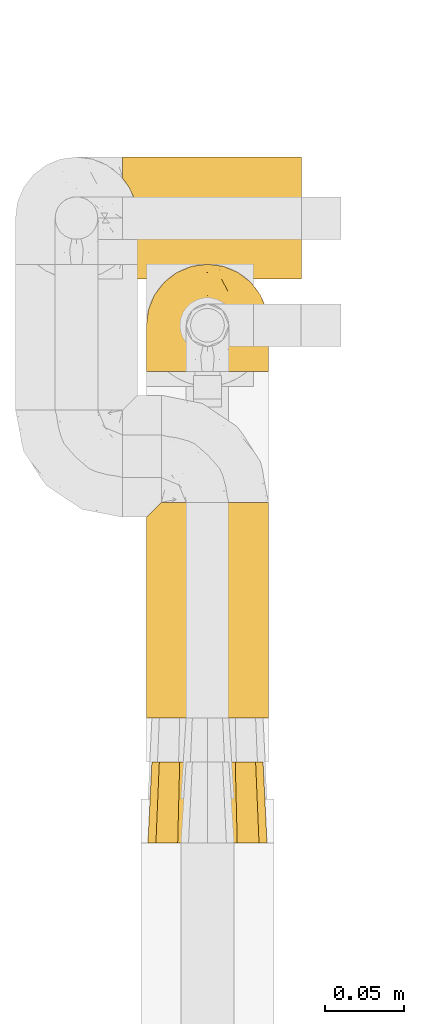
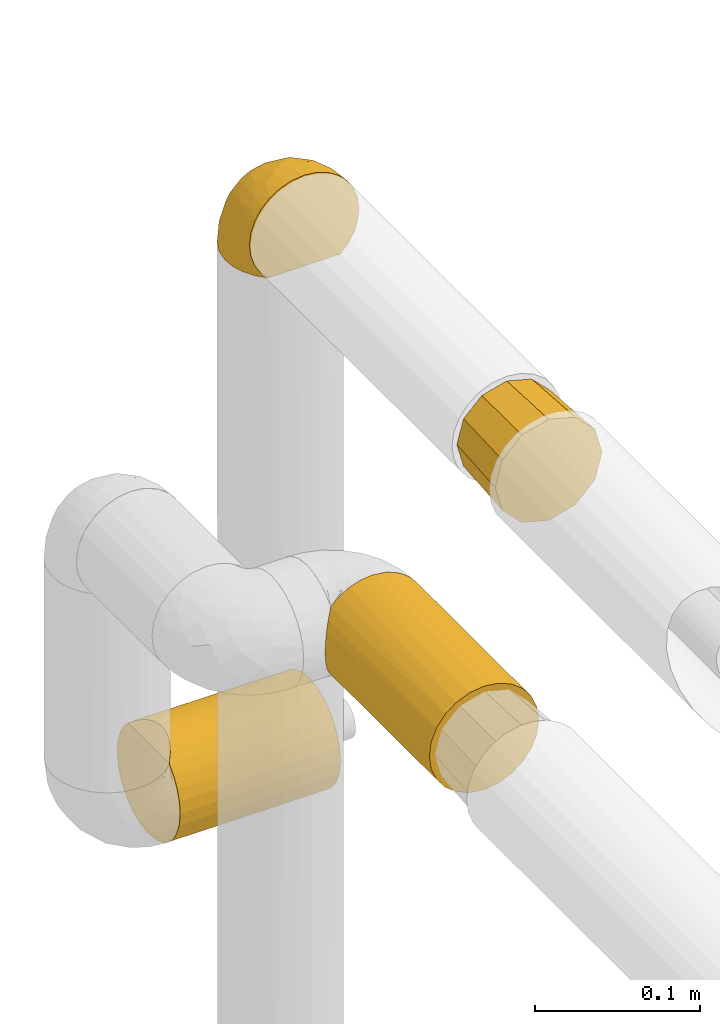
# One storey, part 110 of 827: 4 coverings.
"""IFC2X3 building model written with IfcOpenShell, lengths in millimetres."""

from ifc_helpers import new_model, entity, si_unit, converted_unit, derived_unit, direction, frame, origin, place, context, subcontext, project, spatial, faceted_brep, element, save


model = new_model("IFC2X3")

# Units and contexts
model_context = context("Model", 3, precision=0.01, world=origin(), true_north=direction((6.12303176911189e-17, 1.0)))
body_context = subcontext(model_context, "Body", "Model", "MODEL_VIEW")
ifc_project = project(units=[si_unit("LENGTHUNIT", "METRE", prefix="MILLI"), si_unit("AREAUNIT", "SQUARE_METRE"), si_unit("VOLUMEUNIT", "CUBIC_METRE"), converted_unit("PLANEANGLEUNIT", "DEGREE", entity("IfcRatioMeasure", 0.0174532925199433), si_unit("PLANEANGLEUNIT", "RADIAN"), dimensions=[0, 0, 0, 0, 0, 0, 0]), si_unit("MASSUNIT", "GRAM", prefix="KILO"), derived_unit("MASSDENSITYUNIT", [(si_unit("MASSUNIT", "GRAM", prefix="KILO"), 1), (si_unit("LENGTHUNIT", "METRE"), -3)]), derived_unit("MOMENTOFINERTIAUNIT", [(si_unit("LENGTHUNIT", "METRE"), 4)]), si_unit("TIMEUNIT", "SECOND"), si_unit("FREQUENCYUNIT", "HERTZ"), si_unit("THERMODYNAMICTEMPERATUREUNIT", "DEGREE_CELSIUS"), derived_unit("THERMALTRANSMITTANCEUNIT", [(si_unit("MASSUNIT", "GRAM", prefix="KILO"), 1), (si_unit("THERMODYNAMICTEMPERATUREUNIT", "KELVIN"), -1), (si_unit("TIMEUNIT", "SECOND"), -3)]), derived_unit("VOLUMETRICFLOWRATEUNIT", [(si_unit("LENGTHUNIT", "METRE"), 3), (si_unit("TIMEUNIT", "SECOND"), -1)]), derived_unit("MASSFLOWRATEUNIT", [(si_unit("MASSUNIT", "GRAM", prefix="KILO"), 1), (si_unit("TIMEUNIT", "SECOND"), -1)]), derived_unit("ROTATIONALFREQUENCYUNIT", [(si_unit("TIMEUNIT", "SECOND"), -1)]), si_unit("ELECTRICCURRENTUNIT", "AMPERE"), si_unit("ELECTRICVOLTAGEUNIT", "VOLT"), si_unit("POWERUNIT", "WATT"), si_unit("FORCEUNIT", "NEWTON", prefix="KILO"), si_unit("ILLUMINANCEUNIT", "LUX"), si_unit("LUMINOUSFLUXUNIT", "LUMEN"), si_unit("LUMINOUSINTENSITYUNIT", "CANDELA"), derived_unit("USERDEFINED", [(si_unit("MASSUNIT", "GRAM", prefix="KILO"), -1), (si_unit("LENGTHUNIT", "METRE"), -2), (si_unit("TIMEUNIT", "SECOND"), 3), (si_unit("LUMINOUSFLUXUNIT", "LUMEN"), 1)]), derived_unit("LINEARVELOCITYUNIT", [(si_unit("LENGTHUNIT", "METRE"), 1), (si_unit("TIMEUNIT", "SECOND"), -1)]), si_unit("PRESSUREUNIT", "PASCAL"), derived_unit("USERDEFINED", [(si_unit("LENGTHUNIT", "METRE"), -2), (si_unit("MASSUNIT", "GRAM", prefix="KILO"), 1), (si_unit("TIMEUNIT", "SECOND"), -2)]), derived_unit("LINEARFORCEUNIT", [(si_unit("MASSUNIT", "GRAM", prefix="KILO"), 1), (si_unit("LENGTHUNIT", "METRE"), 1), (si_unit("TIMEUNIT", "SECOND"), -2), (si_unit("LENGTHUNIT", "METRE"), -1)]), derived_unit("PLANARFORCEUNIT", [(si_unit("MASSUNIT", "GRAM", prefix="KILO"), 1), (si_unit("LENGTHUNIT", "METRE"), 1), (si_unit("TIMEUNIT", "SECOND"), -2), (si_unit("LENGTHUNIT", "METRE"), -2)])], contexts=[model_context])

# Site, building, storey
site_placement = place(None, origin())
site = spatial("IfcSite", under=ifc_project, at=site_placement, CompositionType="ELEMENT")
building_placement = place(site_placement, origin())
building = spatial("IfcBuilding", under=site, at=building_placement, CompositionType="ELEMENT")
storey_placement = place(building_placement, frame((0.0, 0.0, 28200.0)))
storey = spatial("IfcBuildingStorey", under=building, at=storey_placement, Name="08", CompositionType="ELEMENT", Elevation=28200.0)

# Coverings
covering_1_placement = place(storey_placement, frame((19736.22, 11790.36, 1773.88)))
element("IfcCovering", 1, at=covering_1_placement, inside=storey, Name=":ADSK_", ObjectType=":ADSK_", PredefinedType="INSULATION", context=body_context, shape_type="Brep", body=[
    faceted_brep([(74.68, 1.6, 47.38), (70.1, 1.6, 54.67), (64.01, 1.6, 60.76), (56.72, 1.6, 65.34), (48.6, 1.6, 68.18), (40.05, 1.6, 69.15), (31.49, 1.6, 68.18), (23.36, 1.6, 65.33), (16.07, 1.6, 60.75), (9.98, 1.6, 54.66), (5.4, 1.6, 47.37), (2.56, 1.6, 39.25), (1.6, 1.6, 30.7), (2.46, 1.6, 22.59), (5.01, 1.6, 14.86), (9.13, 1.6, 7.84), (14.62, 1.6, 1.85), (16.82, 1.6, 1.85), (18.56, 1.6, 1.85), (20.52, 1.6, 1.85), (22.49, 1.6, 1.85), (24.46, 1.6, 1.85), (26.42, 1.6, 1.85), (28.39, 1.6, 1.85), (30.36, 1.6, 1.85), (32.55, 1.6, 1.85), (34.75, 1.6, 1.85), (36.94, 1.6, 1.85), (39.13, 1.6, 1.85), (41.33, 1.6, 1.85), (43.52, 1.6, 1.85), (45.72, 1.6, 1.85), (47.91, 1.6, 1.85), (50.11, 1.6, 1.85), (52.3, 1.6, 1.85), (54.49, 1.6, 1.85), (56.69, 1.6, 1.85), (58.88, 1.6, 1.85), (61.08, 1.6, 1.85), (63.27, 1.6, 1.85), (65.47, 1.6, 1.85), (70.97, 1.6, 7.85), (75.09, 1.6, 14.88), (77.64, 1.6, 22.61), (78.5, 1.6, 30.7), (77.53, 1.6, 39.26), (14.62, 1.85, 1.6), (9.12, 7.85, 1.6), (5.0, 14.87, 1.6), (2.46, 22.6, 1.6), (1.6, 30.7, 1.6), (2.91, 40.65, 1.6), (6.75, 49.92, 1.6), (12.86, 57.88, 1.6), (20.82, 63.99, 1.6), (30.09, 67.84, 1.6), (40.05, 69.15, 1.6), (50.0, 67.84, 1.6), (59.27, 63.99, 1.6), (67.23, 57.88, 1.6), (73.34, 49.92, 1.6), (77.19, 40.65, 1.6), (78.5, 30.7, 1.6), (77.63, 22.6, 1.6), (75.09, 14.87, 1.6), (70.97, 7.85, 1.6), (65.47, 1.85, 1.6), (63.27, 1.85, 1.6), (62.29, 1.85, 1.6), (60.7, 1.85, 1.6), (59.11, 1.85, 1.6), (57.52, 1.85, 1.6), (55.93, 1.85, 1.6), (54.34, 1.85, 1.6), (52.76, 1.85, 1.6), (51.17, 1.85, 1.6), (49.58, 1.85, 1.6), (47.99, 1.85, 1.6), (46.4, 1.85, 1.6), (44.81, 1.85, 1.6), (43.22, 1.85, 1.6), (41.63, 1.85, 1.6), (40.05, 1.85, 1.6), (38.46, 1.85, 1.6), (36.87, 1.85, 1.6), (35.28, 1.85, 1.6), (33.69, 1.85, 1.6), (32.1, 1.85, 1.6), (30.51, 1.85, 1.6), (28.92, 1.85, 1.6), (27.33, 1.85, 1.6), (25.37, 1.85, 1.6), (23.4, 1.85, 1.6), (21.21, 1.85, 1.6), (19.01, 1.85, 1.6), (16.82, 1.85, 1.6), (42.32, 1.77, 1.78), (44.02, 1.78, 1.77), (47.13, 1.77, 1.78), (48.74, 1.77, 1.77), (23.57, 1.76, 1.79), (25.13, 1.77, 1.78), (61.34, 1.79, 1.76), (22.02, 1.78, 1.77), (29.72, 1.78, 1.77), (56.73, 1.78, 1.76), (55.14, 1.78, 1.77), (37.66, 1.78, 1.77), (64.12, 1.74, 1.8), (28.13, 1.78, 1.76), (26.62, 1.78, 1.77), (31.46, 1.77, 1.78), (16.16, 1.78, 1.77), (39.16, 1.78, 1.77), (50.37, 1.78, 1.76), (17.69, 1.77, 1.77), (19.17, 1.77, 1.78), (62.78, 1.77, 1.77), (58.35, 1.78, 1.77), (45.53, 1.78, 1.77), (59.91, 1.77, 1.78), (65.47, 1.77, 1.77), (65.47, 1.72, 1.8), (65.47, 1.66, 1.82), (14.62, 1.77, 1.77), (14.62, 1.8, 1.72), (14.62, 1.82, 1.66), (20.59, 1.79, 1.76), (32.99, 1.78, 1.77), (34.48, 1.79, 1.76), (51.91, 1.78, 1.77), (65.47, 1.82, 1.66), (65.47, 1.8, 1.72), (53.48, 1.76, 1.78), (14.62, 1.66, 1.82), (14.62, 1.72, 1.8), (40.77, 1.78, 1.77), (35.97, 1.77, 1.78), (7.84, 9.41, 3.72), (3.53, 17.65, 7.41), (8.32, 7.41, 6.13), (1.6, 21.47, 21.47), (2.19, 15.21, 19.34), (1.6, 16.15, 26.8), (1.6, 28.75, 8.87), (4.57, 13.67, 9.2), (3.96, 12.79, 12.79), (2.28, 19.18, 14.62), (1.6, 29.16, 7.34), (7.69, 9.04, 5.33), (3.53, 7.41, 17.64), (8.32, 5.74, 7.7), (7.84, 3.72, 9.41), (1.6, 8.87, 28.75), (1.6, 26.8, 16.15), (4.34, 9.53, 14.14), (1.6, 7.34, 29.16), (29.63, 37.63, 57.02), (27.34, 17.92, 64.92), (40.05, 27.45, 64.0), (2.39, 37.01, 11.92), (2.43, 34.22, 19.16), (9.07, 45.87, 28.65), (16.64, 56.57, 24.62), (9.54, 52.31, 15.19), (4.52, 42.07, 18.36), (4.52, 44.74, 9.2), (7.49, 21.49, 46.98), (7.49, 11.02, 50.24), (12.85, 15.64, 56.1), (2.35, 26.02, 28.97), (22.66, 36.59, 54.46), (32.9, 65.49, 21.34), (25.33, 63.99, 18.4), (40.05, 15.2, 66.44), (16.64, 60.27, 12.07), (19.99, 45.25, 45.49), (16.37, 35.21, 50.57), (3.26, 22.52, 36.04), (3.75, 12.03, 42.07), (19.58, 13.32, 62.12), (7.5, 35.9, 37.37), (4.04, 33.87, 29.39), (13.94, 25.73, 53.59), (19.58, 26.34, 58.06), (28.21, 46.78, 49.27), (24.75, 59.54, 29.63), (31.42, 60.18, 33.21), (26.2, 53.93, 40.1), (33.36, 53.36, 44.08), (40.05, 49.36, 49.36), (40.05, 38.4, 56.68), (40.05, 66.44, 15.2), (16.14, 50.09, 35.57), (12.85, 41.08, 41.7), (10.47, 31.14, 46.4), (6.49, 28.19, 41.41), (40.05, 64.0, 27.45), (40.05, 56.68, 38.4), (75.57, 43.9, 12.99), (47.37, 65.46, 21.33), (52.91, 52.22, 42.89), (50.46, 37.61, 57.04), (67.23, 15.64, 56.11), (60.5, 13.31, 62.13), (70.55, 50.02, 21.89), (63.45, 59.28, 16.62), (62.61, 53.05, 32.9), (72.6, 21.48, 46.99), (72.6, 11.01, 50.25), (76.34, 12.03, 42.08), (59.34, 41.02, 49.91), (77.76, 35.39, 15.6), (78.5, 26.8, 16.15), (78.5, 28.75, 8.87), (78.5, 7.34, 29.16), (53.16, 65.81, 13.16), (70.55, 53.28, 10.83), (48.88, 59.8, 33.8), (54.76, 61.82, 25.02), (52.74, 17.91, 64.92), (71.93, 41.4, 32.83), (75.79, 40.48, 20.56), (60.5, 26.34, 58.07), (77.86, 31.68, 21.46), (77.64, 27.68, 28.1), (78.5, 16.15, 26.8), (78.5, 21.47, 21.47), (67.23, 28.05, 51.29), (76.82, 22.54, 36.04), (78.5, 8.87, 28.75), (77.8, 37.3, 8.45), (67.23, 41.07, 41.73), (73.2, 32.24, 39.27), (67.66, 47.4, 33.56), (75.99, 35.77, 27.29), (76.57, 17.65, 7.41), (73.21, 11.06, 3.51), (71.93, 8.55, 4.68), (71.07, 6.63, 5.52), (75.09, 12.77, 8.75), (76.13, 12.79, 12.79), (76.57, 7.41, 17.65), (77.69, 18.97, 13.9), (72.26, 3.72, 9.42), (71.77, 5.76, 7.68), (77.9, 15.21, 19.33), (75.75, 9.52, 14.13)], [[[0, 1, 2, 3, 4, 5, 6, 7, 8, 9, 10, 11, 12, 13, 14, 15, 16, 17, 18, 19, 20, 21, 22, 23, 24, 25, 26, 27, 28, 29, 30, 31, 32, 33, 34, 35, 36, 37, 38, 39, 40, 41, 42, 43, 44, 45]], [[46, 47, 48, 49, 50, 51, 52, 53, 54, 55, 56, 57, 58, 59, 60, 61, 62, 63, 64, 65, 66, 67, 68, 69, 70, 71, 72, 73, 74, 75, 76, 77, 78, 79, 80, 81, 82, 83, 84, 85, 86, 87, 88, 89, 90, 91, 92, 93, 94, 95]], [[96, 97, 30]], [[98, 77, 99]], [[100, 101, 21]], [[69, 68, 102]], [[20, 19, 103]], [[24, 23, 104]], [[20, 103, 100]], [[72, 105, 106]], [[84, 83, 107]], [[89, 88, 104]], [[108, 67, 66]], [[109, 110, 90]], [[111, 25, 24]], [[112, 17, 16]], [[82, 113, 83]], [[109, 23, 22]], [[114, 76, 75]], [[105, 36, 106]], [[104, 111, 24]], [[18, 115, 116]], [[97, 96, 80]], [[67, 108, 117]], [[105, 71, 118]], [[31, 97, 119]], [[102, 120, 69]], [[108, 121, 122, 123, 40]], [[112, 95, 115]], [[17, 115, 18]], [[94, 116, 115]], [[117, 68, 67]], [[38, 117, 39]], [[112, 124, 125, 126, 46]], [[17, 112, 115]], [[70, 120, 118]], [[39, 117, 108]], [[120, 38, 37]], [[120, 37, 118]], [[120, 70, 69]], [[116, 94, 127]], [[128, 86, 129]], [[117, 38, 102]], [[74, 130, 75]], [[99, 33, 32]], [[115, 95, 94]], [[39, 108, 40]], [[108, 66, 131, 132, 121]], [[105, 72, 71]], [[118, 37, 36]], [[71, 70, 118]], [[35, 106, 36]], [[36, 105, 118]], [[35, 133, 106]], [[74, 73, 133]], [[106, 133, 73]], [[99, 114, 33]], [[133, 35, 34]], [[73, 72, 106]], [[95, 112, 46]], [[112, 16, 134, 135, 124]], [[130, 114, 75]], [[99, 76, 114]], [[114, 130, 33]], [[34, 33, 130]], [[78, 77, 98]], [[98, 119, 78]], [[130, 133, 34]], [[133, 130, 74]], [[79, 97, 80]], [[98, 99, 32]], [[98, 32, 31]], [[77, 76, 99]], [[97, 79, 119]], [[136, 96, 29]], [[30, 97, 31]], [[136, 29, 28]], [[81, 80, 96]], [[29, 96, 30]], [[31, 119, 98]], [[119, 79, 78]], [[96, 136, 81]], [[82, 81, 136]], [[113, 107, 83]], [[84, 107, 137]], [[107, 27, 137]], [[113, 28, 107]], [[27, 107, 28]], [[85, 84, 137]], [[137, 27, 26]], [[113, 136, 28]], [[136, 113, 82]], [[109, 89, 104]], [[86, 85, 129]], [[89, 109, 90]], [[111, 87, 128]], [[26, 129, 137]], [[88, 111, 104]], [[25, 111, 128]], [[22, 110, 109]], [[23, 109, 104]], [[110, 91, 90]], [[100, 92, 101]], [[110, 22, 101]], [[91, 110, 101]], [[116, 19, 18]], [[111, 88, 87]], [[127, 103, 19]], [[25, 128, 26]], [[86, 128, 87]], [[128, 129, 26]], [[137, 129, 85]], [[120, 102, 38]], [[117, 102, 68]], [[91, 101, 92]], [[21, 101, 22]], [[93, 92, 103]], [[100, 21, 20]], [[100, 103, 92]], [[127, 93, 103]], [[93, 127, 94]], [[116, 127, 19]], [[126, 138, 47]], [[48, 138, 139]], [[140, 125, 124]], [[141, 142, 143]], [[144, 49, 139]], [[145, 140, 146]], [[48, 139, 49]], [[139, 145, 147]], [[49, 144, 148, 50]], [[126, 125, 149]], [[14, 13, 150]], [[151, 146, 140]], [[149, 140, 145]], [[152, 151, 135]], [[152, 14, 150]], [[16, 15, 134]], [[13, 153, 150]], [[124, 151, 140]], [[141, 147, 142]], [[14, 152, 15]], [[15, 152, 134]], [[47, 46, 126]], [[139, 154, 144]], [[138, 48, 47]], [[125, 140, 149]], [[135, 134, 152]], [[146, 155, 142]], [[145, 146, 147]], [[149, 139, 138]], [[147, 141, 154]], [[147, 146, 142]], [[139, 147, 154]], [[139, 149, 145]], [[149, 138, 126]], [[155, 146, 151]], [[150, 143, 142]], [[152, 155, 151]], [[150, 142, 155]], [[13, 12, 156, 153]], [[153, 143, 150]], [[152, 150, 155]], [[151, 124, 135]], [[157, 158, 159]], [[160, 154, 161]], [[162, 163, 164]], [[165, 166, 160]], [[167, 168, 169]], [[141, 170, 161]], [[156, 12, 11]], [[158, 157, 171]], [[172, 55, 173]], [[158, 6, 174]], [[175, 54, 53]], [[52, 166, 164]], [[52, 164, 53]], [[54, 175, 173]], [[166, 52, 51]], [[176, 177, 171]], [[178, 143, 179]], [[156, 11, 179]], [[8, 7, 180]], [[169, 9, 8]], [[179, 143, 153, 156]], [[179, 11, 10]], [[168, 179, 10]], [[181, 162, 182]], [[179, 167, 178]], [[183, 184, 177]], [[183, 169, 184]], [[176, 171, 185]], [[172, 186, 187]], [[158, 7, 6]], [[159, 158, 174]], [[184, 180, 158]], [[54, 173, 55]], [[180, 169, 8]], [[188, 189, 187]], [[9, 168, 10]], [[186, 188, 187]], [[190, 157, 159, 191]], [[55, 172, 192]], [[176, 193, 194]], [[161, 170, 182]], [[162, 164, 165]], [[175, 164, 163]], [[51, 50, 148]], [[167, 195, 196]], [[178, 182, 170]], [[6, 5, 174]], [[158, 180, 7]], [[169, 180, 184]], [[169, 168, 9]], [[179, 168, 167]], [[182, 162, 165]], [[162, 194, 193]], [[161, 165, 160]], [[195, 181, 196]], [[192, 172, 197]], [[192, 56, 55]], [[189, 190, 198]], [[198, 197, 187]], [[172, 187, 197]], [[185, 189, 188]], [[198, 187, 189]], [[186, 172, 173]], [[173, 163, 186]], [[193, 186, 163]], [[176, 185, 188]], [[185, 157, 190]], [[188, 186, 193]], [[177, 176, 194]], [[188, 193, 176]], [[162, 193, 163]], [[195, 177, 194]], [[171, 177, 184]], [[181, 195, 194]], [[183, 167, 169]], [[162, 181, 194]], [[196, 182, 178]], [[158, 171, 184]], [[171, 157, 185]], [[177, 195, 183]], [[167, 183, 195]], [[182, 196, 181]], [[178, 170, 143]], [[178, 167, 196]], [[164, 175, 53]], [[173, 175, 163]], [[160, 51, 148]], [[164, 166, 165]], [[51, 160, 166]], [[160, 148, 144, 154]], [[141, 161, 154]], [[182, 165, 161]], [[190, 189, 185]], [[143, 170, 141]], [[60, 199, 61]], [[197, 200, 192]], [[201, 190, 202]], [[200, 57, 192]], [[203, 204, 2]], [[205, 206, 207]], [[208, 209, 210]], [[211, 207, 201]], [[212, 213, 214]], [[45, 215, 210]], [[216, 206, 58]], [[45, 44, 215]], [[59, 217, 60]], [[60, 217, 199]], [[0, 45, 210]], [[218, 201, 219]], [[202, 159, 220]], [[205, 221, 222]], [[223, 204, 203]], [[1, 203, 2]], [[57, 200, 216]], [[220, 3, 204]], [[220, 174, 4]], [[1, 0, 209]], [[212, 224, 213]], [[225, 226, 227]], [[228, 223, 203]], [[208, 210, 229]], [[210, 226, 229]], [[3, 220, 4]], [[58, 206, 59]], [[209, 203, 1]], [[202, 220, 223]], [[228, 203, 208]], [[202, 211, 201]], [[3, 2, 204]], [[202, 190, 191, 159]], [[210, 215, 230, 226]], [[199, 212, 231]], [[232, 233, 221]], [[233, 208, 229]], [[207, 206, 219]], [[217, 206, 205]], [[227, 224, 225]], [[233, 232, 228]], [[201, 207, 219]], [[234, 232, 221]], [[218, 219, 200]], [[202, 223, 211]], [[174, 220, 159]], [[174, 5, 4]], [[61, 231, 62]], [[220, 204, 223]], [[210, 209, 0]], [[203, 209, 208]], [[225, 233, 229]], [[224, 227, 213]], [[221, 233, 235]], [[57, 56, 192]], [[198, 218, 197]], [[200, 219, 216]], [[201, 198, 190]], [[197, 218, 200]], [[198, 201, 218]], [[206, 216, 219]], [[58, 57, 216]], [[231, 212, 214]], [[222, 212, 199]], [[228, 211, 223]], [[207, 211, 232]], [[62, 231, 214]], [[199, 231, 61]], [[233, 228, 208]], [[211, 228, 232]], [[222, 221, 235]], [[234, 205, 207]], [[206, 217, 59]], [[199, 217, 205]], [[205, 222, 199]], [[224, 222, 235]], [[222, 224, 212]], [[224, 235, 225]], [[233, 225, 235]], [[226, 225, 229]], [[205, 234, 221]], [[207, 232, 234]], [[63, 214, 236]], [[214, 213, 236]], [[214, 63, 62]], [[237, 236, 238]], [[238, 132, 131]], [[236, 237, 64]], [[239, 240, 241]], [[63, 236, 64]], [[131, 66, 65]], [[237, 131, 65]], [[242, 230, 43]], [[237, 65, 64]], [[239, 121, 132]], [[42, 242, 43]], [[241, 240, 243]], [[41, 123, 244]], [[43, 230, 215, 44]], [[244, 122, 245]], [[227, 246, 243]], [[241, 243, 246]], [[121, 239, 245]], [[41, 40, 123]], [[132, 238, 239]], [[244, 42, 41]], [[131, 237, 238]], [[240, 239, 238]], [[245, 239, 241]], [[247, 241, 246]], [[247, 244, 245]], [[238, 236, 240]], [[243, 236, 213]], [[236, 243, 240]], [[226, 246, 227]], [[243, 213, 227]], [[226, 242, 246]], [[241, 247, 245]], [[246, 242, 247]], [[244, 247, 242]], [[242, 226, 230]], [[42, 244, 242]], [[122, 244, 123]], [[122, 121, 245]]]),
])
covering_2_placement = place(storey_placement, frame((19737.17, 11495.06, 1765.48)))
element("IfcCovering", 2, at=covering_2_placement, inside=storey, Name=":ADSK_", ObjectType=":ADSK_", PredefinedType="INSULATION", context=body_context, shape_type="Brep", body=[
    faceted_brep([(71.75, 51.0, 47.85), (74.1, 51.0, 39.1), (71.75, 51.0, 30.35), (69.41, 51.0, 21.6), (63.0, 51.0, 15.19), (56.6, 51.0, 8.78), (47.85, 51.0, 6.44), (39.1, 51.0, 4.1), (30.35, 51.0, 6.44), (21.6, 51.0, 8.78), (15.19, 51.0, 15.19), (8.78, 51.0, 21.6), (6.44, 51.0, 30.35), (4.1, 51.0, 39.1), (6.44, 51.0, 47.85), (8.78, 51.0, 56.6), (15.19, 51.0, 63.0), (21.6, 51.0, 69.41), (30.35, 51.0, 71.75), (39.1, 51.0, 74.1), (47.85, 51.0, 71.75), (56.6, 51.0, 69.41), (63.0, 51.0, 63.0), (69.41, 51.0, 56.6), (20.35, 0.0, 71.57), (13.48, 0.0, 64.71), (6.62, 0.0, 57.85), (5.04, 0.0, 51.96), (3.32, 0.0, 45.53), (1.6, 0.0, 39.1), (3.32, 0.0, 32.66), (5.04, 0.0, 26.23), (6.62, 0.0, 20.35), (13.48, 0.0, 13.48), (20.35, 0.0, 6.62), (26.23, 0.0, 5.04), (32.66, 0.0, 3.32), (39.1, 0.0, 1.6), (45.53, 0.0, 3.32), (51.96, 0.0, 5.04), (57.85, 0.0, 6.62), (64.71, 0.0, 13.48), (71.57, 0.0, 20.35), (73.15, 0.0, 26.23), (74.87, 0.0, 32.66), (76.6, 0.0, 39.1), (74.87, 0.0, 45.53), (73.15, 0.0, 51.96), (71.57, 0.0, 57.85), (64.71, 0.0, 64.71), (57.85, 0.0, 71.57), (51.96, 0.0, 73.15), (45.53, 0.0, 74.87), (39.1, 0.0, 76.6), (32.66, 0.0, 74.87), (26.23, 0.0, 73.15)], [[[0, 1, 2, 3, 4, 5, 6, 7, 8, 9, 10, 11, 12, 13, 14, 15, 16, 17, 18, 19, 20, 21, 22, 23]], [[24, 25, 26, 27, 28, 29, 30, 31, 32, 33, 34, 35, 36, 37, 38, 39, 40, 41, 42, 43, 44, 45, 46, 47, 48, 49, 50, 51, 52, 53, 54, 55]], [[5, 40, 39, 38, 37, 7, 6]], [[42, 41, 40, 5, 4, 3]], [[45, 44, 43, 42, 3, 2, 1]], [[11, 32, 31, 30, 29, 13, 12]], [[34, 33, 32, 11, 10, 9]], [[37, 36, 35, 34, 9, 8, 7]], [[17, 24, 55, 54, 53, 19, 18]], [[26, 25, 24, 17, 16, 15]], [[29, 28, 27, 26, 15, 14, 13]], [[23, 48, 47, 46, 45, 1, 0]], [[50, 49, 48, 23, 22, 21]], [[53, 52, 51, 50, 21, 20, 19]]]),
])
covering_3_placement = place(storey_placement, frame((19721.27, 11848.56, 1312.95)))
element("IfcCovering", 3, at=covering_3_placement, inside=storey, Name=":ADSK_", ObjectType=":ADSK_", PredefinedType="INSULATION", context=body_context, shape_type="Brep", body=[
    faceted_brep([(1.6, 20.8, 6.74), (1.6, 12.84, 12.84), (1.6, 6.74, 20.8), (1.6, 2.9, 30.06), (1.6, 1.6, 40.0), (1.6, 2.48, 48.2), (1.6, 5.09, 56.01), (1.6, 9.31, 63.08), (1.6, 14.94, 69.1), (1.6, 65.05, 69.1), (1.6, 70.68, 63.08), (1.6, 74.9, 56.01), (1.6, 77.51, 48.2), (1.6, 78.4, 40.0), (1.6, 77.09, 30.06), (1.6, 73.25, 20.8), (1.6, 67.15, 12.84), (1.6, 59.2, 6.74), (1.6, 49.93, 2.9), (1.6, 40.0, 1.6), (1.6, 30.06, 2.9), (114.1, 20.8, 6.74), (114.1, 30.06, 2.9), (114.1, 40.0, 1.6), (114.1, 49.93, 2.9), (114.1, 59.2, 6.74), (114.1, 67.15, 12.84), (114.1, 73.25, 20.8), (114.1, 77.09, 30.06), (114.1, 78.4, 40.0), (114.1, 77.09, 49.93), (114.1, 73.25, 59.2), (114.1, 67.15, 67.15), (114.1, 59.2, 73.25), (114.1, 49.93, 77.09), (114.1, 40.0, 78.4), (114.1, 30.06, 77.09), (114.1, 20.8, 73.25), (114.1, 12.84, 67.15), (114.1, 6.74, 59.2), (114.1, 2.9, 49.93), (114.1, 1.6, 40.0), (114.1, 2.9, 30.06), (114.1, 6.74, 20.8), (114.1, 12.84, 12.84), (8.5, 26.63, 76.0), (10.29, 33.21, 77.79), (10.9, 40.0, 78.4), (5.57, 20.48, 73.07), (10.29, 46.78, 77.79), (8.5, 53.36, 76.0), (5.57, 59.51, 73.07)], [[[0, 1, 2, 3, 4, 5, 6, 7, 8, 9, 10, 11, 12, 13, 14, 15, 16, 17, 18, 19, 20]], [[21, 22, 23, 24, 25, 26, 27, 28, 29, 30, 31, 32, 33, 34, 35, 36, 37, 38, 39, 40, 41, 42, 43, 44]], [[28, 27, 15, 14]], [[29, 28, 14, 13]], [[27, 26, 16, 15]], [[18, 17, 25, 24]], [[19, 18, 24, 23]], [[26, 25, 17, 16]], [[20, 19, 23, 22]], [[0, 20, 22, 21]], [[21, 44, 1, 0]], [[3, 2, 43, 42]], [[4, 3, 42, 41]], [[44, 43, 2, 1]], [[5, 41, 40]], [[6, 40, 39]], [[7, 39, 38]], [[4, 41, 5]], [[5, 40, 6]], [[39, 7, 6]], [[38, 8, 7]], [[45, 37, 36]], [[36, 35, 46]], [[47, 46, 35]], [[48, 8, 37]], [[46, 45, 36]], [[48, 37, 45]], [[37, 8, 38]], [[49, 47, 35]], [[49, 35, 34]], [[50, 34, 33]], [[50, 49, 34]], [[9, 51, 33]], [[50, 33, 51]], [[33, 32, 9]], [[10, 32, 31]], [[11, 31, 30]], [[12, 30, 29]], [[10, 31, 11]], [[11, 30, 12]], [[29, 13, 12]], [[32, 10, 9]], [[8, 48, 45, 46, 47, 49, 50, 51, 9]]]),
])
covering_4_placement = place(storey_placement, frame((19736.27, 11573.56, 1518.17)))
element("IfcCovering", 4, at=covering_4_placement, inside=storey, Name=":ADSK_", ObjectType=":ADSK_", PredefinedType="INSULATION", context=body_context, shape_type="Brep", body=[
    faceted_brep([(23.98, 135.9, 74.9), (31.79, 135.9, 77.51), (40.0, 135.9, 78.4), (49.93, 135.9, 77.09), (59.2, 135.9, 73.25), (67.15, 135.9, 67.15), (73.25, 135.9, 59.2), (77.09, 135.9, 49.93), (78.4, 135.9, 40.0), (77.09, 135.9, 30.06), (73.25, 135.9, 20.8), (67.15, 135.9, 12.84), (59.2, 135.9, 6.74), (49.93, 135.9, 2.9), (40.0, 135.9, 1.6), (31.79, 135.9, 2.48), (23.98, 135.9, 5.09), (16.91, 135.9, 9.31), (10.9, 135.9, 14.94), (10.9, 135.9, 65.05), (16.91, 135.9, 70.68), (20.8, 0.0, 73.25), (12.84, 0.0, 67.15), (6.74, 0.0, 59.2), (2.9, 0.0, 49.93), (1.6, 0.0, 40.0), (2.9, 0.0, 30.06), (6.74, 0.0, 20.8), (12.84, 0.0, 12.84), (20.8, 0.0, 6.74), (30.06, 0.0, 2.9), (40.0, 0.0, 1.6), (49.93, 0.0, 2.9), (59.2, 0.0, 6.74), (67.15, 0.0, 12.84), (73.25, 0.0, 20.8), (77.09, 0.0, 30.06), (78.4, 0.0, 40.0), (77.09, 0.0, 49.93), (73.25, 0.0, 59.2), (67.15, 0.0, 67.15), (59.2, 0.0, 73.25), (49.93, 0.0, 77.09), (40.0, 0.0, 78.4), (30.06, 0.0, 77.09), (4.0, 129.0, 26.63), (2.2, 127.2, 33.21), (1.6, 126.6, 40.0), (6.92, 131.93, 20.48), (2.2, 127.2, 46.78), (4.0, 129.0, 53.36), (6.92, 131.93, 59.51)], [[[0, 1, 2, 3, 4, 5, 6, 7, 8, 9, 10, 11, 12, 13, 14, 15, 16, 17, 18, 19, 20]], [[21, 22, 23, 24, 25, 26, 27, 28, 29, 30, 31, 32, 33, 34, 35, 36, 37, 38, 39, 40, 41, 42, 43, 44]], [[36, 35, 10, 9]], [[37, 36, 9, 8]], [[35, 34, 11, 10]], [[13, 12, 33, 32]], [[14, 13, 32, 31]], [[34, 33, 12, 11]], [[15, 31, 30]], [[16, 30, 29]], [[17, 29, 28]], [[14, 31, 15]], [[15, 30, 16]], [[29, 17, 16]], [[28, 18, 17]], [[45, 27, 26]], [[26, 25, 46]], [[47, 46, 25]], [[48, 18, 27]], [[46, 45, 26]], [[48, 27, 45]], [[27, 18, 28]], [[49, 47, 25]], [[49, 25, 24]], [[50, 24, 23]], [[50, 49, 24]], [[19, 51, 23]], [[50, 23, 51]], [[23, 22, 19]], [[20, 22, 21]], [[0, 21, 44]], [[1, 44, 43]], [[20, 21, 0]], [[0, 44, 1]], [[43, 2, 1]], [[22, 20, 19]], [[3, 2, 43, 42]], [[4, 3, 42, 41]], [[41, 40, 5, 4]], [[7, 6, 39, 38]], [[8, 7, 38, 37]], [[40, 39, 6, 5]], [[46, 47, 49, 50, 51, 19, 18, 48, 45]]]),
])

save(model, "model.ifc")
